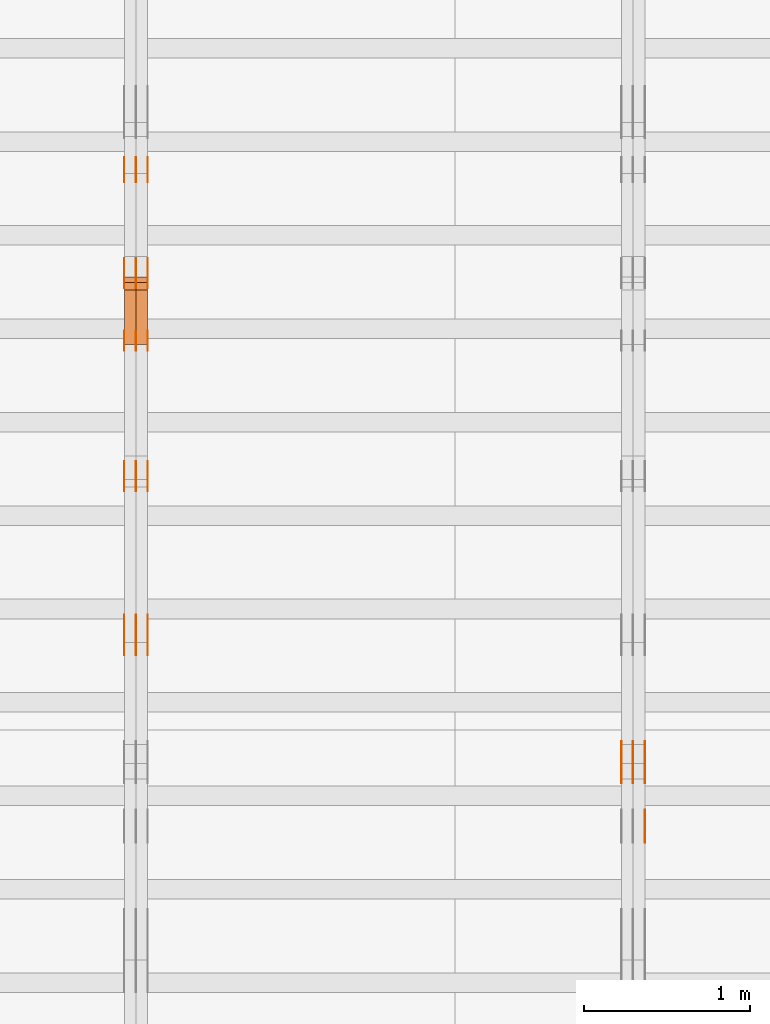
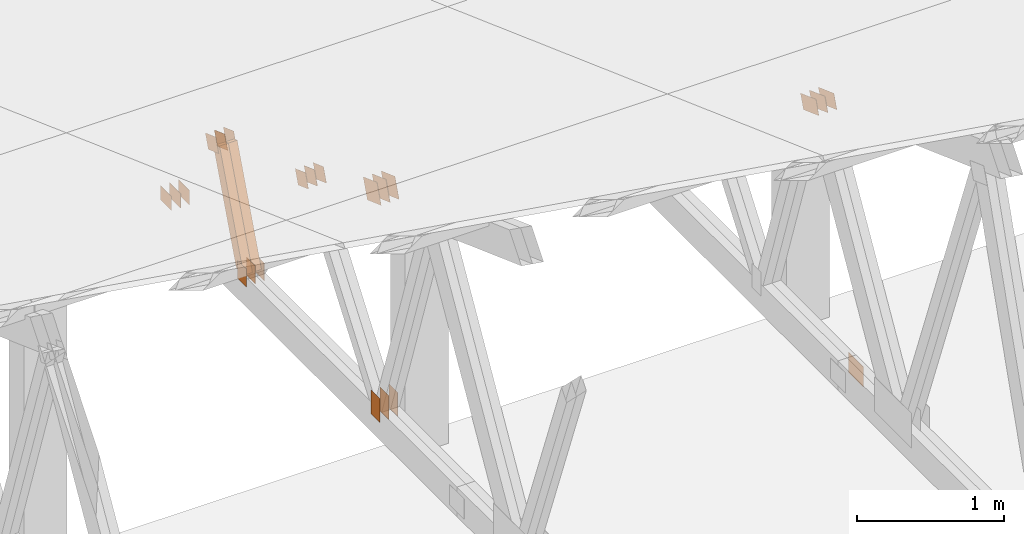
# One storey, part 165 of 189: 31 proxies.
"""IFC2X3 building model written with IfcOpenShell, lengths in millimetres."""

from ifc_helpers import new_model, entity, si_unit, converted_unit, derived_unit, direction, frame, frame_2d, origin, origin_2d_with_axis, place, context, subcontext, project, spatial, polyline, rectangle, outline, extrude, source, transform, mapped, material, type_object, type_shapes, element, save


model = new_model("IFC2X3")

# Units and contexts
model_context = context("Model", 3, precision=0.01, world=origin(), true_north=direction((6.12303176911189e-17, 1.0)))
body_context = subcontext(model_context, "Body", "Model", "MODEL_VIEW")
ifc_project = project(units=[si_unit("LENGTHUNIT", "METRE", prefix="MILLI"), si_unit("AREAUNIT", "SQUARE_METRE"), si_unit("VOLUMEUNIT", "CUBIC_METRE"), converted_unit("PLANEANGLEUNIT", "DEGREE", entity("IfcRatioMeasure", 0.0174532925199433), si_unit("PLANEANGLEUNIT", "RADIAN"), dimensions=[0, 0, 0, 0, 0, 0, 0]), si_unit("MASSUNIT", "GRAM", prefix="KILO"), derived_unit("MASSDENSITYUNIT", [(si_unit("MASSUNIT", "GRAM", prefix="KILO"), 1), (si_unit("LENGTHUNIT", "METRE"), -3)]), si_unit("TIMEUNIT", "SECOND"), si_unit("FREQUENCYUNIT", "HERTZ"), si_unit("THERMODYNAMICTEMPERATUREUNIT", "DEGREE_CELSIUS"), derived_unit("THERMALTRANSMITTANCEUNIT", [(si_unit("MASSUNIT", "GRAM", prefix="KILO"), 1), (si_unit("THERMODYNAMICTEMPERATUREUNIT", "KELVIN"), -1), (si_unit("TIMEUNIT", "SECOND"), -3)]), derived_unit("VOLUMETRICFLOWRATEUNIT", [(si_unit("LENGTHUNIT", "METRE"), 3), (si_unit("TIMEUNIT", "SECOND"), -1)]), si_unit("ELECTRICCURRENTUNIT", "AMPERE"), si_unit("ELECTRICVOLTAGEUNIT", "VOLT"), si_unit("POWERUNIT", "WATT"), si_unit("FORCEUNIT", "NEWTON"), si_unit("ILLUMINANCEUNIT", "LUX"), si_unit("LUMINOUSFLUXUNIT", "LUMEN"), si_unit("LUMINOUSINTENSITYUNIT", "CANDELA"), derived_unit("USERDEFINED", [(si_unit("MASSUNIT", "GRAM", prefix="KILO"), -1), (si_unit("LENGTHUNIT", "METRE"), -2), (si_unit("TIMEUNIT", "SECOND"), 3), (si_unit("LUMINOUSFLUXUNIT", "LUMEN"), 1)]), derived_unit("LINEARVELOCITYUNIT", [(si_unit("LENGTHUNIT", "METRE"), 1), (si_unit("TIMEUNIT", "SECOND"), -1)]), si_unit("PRESSUREUNIT", "PASCAL"), derived_unit("USERDEFINED", [(si_unit("LENGTHUNIT", "METRE"), -2), (si_unit("MASSUNIT", "GRAM", prefix="KILO"), 1), (si_unit("TIMEUNIT", "SECOND"), -2)])], contexts=[model_context])

# Site, building, storey
site_placement = place(None, origin())
site = spatial("IfcSite", under=ifc_project, at=site_placement, CompositionType="ELEMENT")
building_placement = place(site_placement, origin())
building = spatial("IfcBuilding", under=site, at=building_placement, CompositionType="ELEMENT")
storey_placement = place(building_placement, origin())
storey = spatial("IfcBuildingStorey", under=building, at=storey_placement, Name="Default", CompositionType="ELEMENT", Elevation=0.0)

# Proxies
ifc_material_1 = material(Name="IfcSurfaceStyle #201218")
building_element_proxy_type_1 = type_object("IfcBuildingElementProxyType", PredefinedType="NOTDEFINED", material=ifc_material_1)
shared_shape_1 = source(origin(), body_context, "Body", "SweptSolid", [
    extrude(outline(polyline([(-112.499846801582, -59.999986193028), (112.499924372729, -59.999986193028), (112.499888552087, 59.999986193028), (-112.499966123235, 59.999986193028), (-112.499846801582, -59.999986193028)])), frame((112.499989807712, 60.0001003787081, 0.0), z_axis=(0.0, 0.0, 1.0), x_axis=(-1.0, 0.0, 0.0)), (0.0, 0.0, 1.0), 1.3),
])
type_shapes(building_element_proxy_type_1, [shared_shape_1])
proxy_1_placement = place(building_placement, frame((36301.3, 24040.8868138992, 2049.61031693104), z_axis=(-1.0, 0.0, 0.0), x_axis=(0.0, -0.939692620785908, 0.342020143325669)))
element("IfcBuildingElementProxy", 1, at=proxy_1_placement, inside=storey, type_object=building_element_proxy_type_1, material=ifc_material_1, context=body_context, shape_type="MappedRepresentation", body=[
    mapped(shared_shape_1, transform((0.0, 0.0, 0.0), scale=1.0)),
])
ifc_material_2 = material(Name="IfcSurfaceStyle #201161")
building_element_proxy_type_2 = type_object("IfcBuildingElementProxyType", PredefinedType="NOTDEFINED", material=ifc_material_2)
shared_shape_2 = source(origin(), body_context, "Body", "SweptSolid", [
    extrude(outline(polyline([(-112.499846801582, -59.999986193028), (112.499924372729, -59.999986193028), (112.499888552087, 59.999986193028), (-112.499966123235, 59.999986193028), (-112.499846801582, -59.999986193028)])), frame((112.499989807712, 60.0001003787081, 0.0), z_axis=(0.0, 0.0, 1.0), x_axis=(-1.0, 0.0, 0.0)), (0.0, 0.0, 1.0), 1.29999999999998),
])
type_shapes(building_element_proxy_type_2, [shared_shape_2])
proxy_2_placement = place(building_placement, frame((36230.0, 24040.8868138992, 2049.61031693104), z_axis=(-1.0, 0.0, 0.0), x_axis=(0.0, -0.939692620785908, 0.342020143325669)))
element("IfcBuildingElementProxy", 2, at=proxy_2_placement, inside=storey, type_object=building_element_proxy_type_2, material=ifc_material_2, context=body_context, shape_type="MappedRepresentation", body=[
    mapped(shared_shape_2, transform((0.0, 0.0, 0.0), scale=1.0)),
])
ifc_material_3 = material(Name="IfcSurfaceStyle #201104")
building_element_proxy_type_3 = type_object("IfcBuildingElementProxyType", PredefinedType="NOTDEFINED", material=ifc_material_3)
shared_shape_3 = source(origin(), body_context, "Body", "SweptSolid", [
    extrude(outline(polyline([(-112.499846801582, -59.999986193028), (112.499924372729, -59.999986193028), (112.499888552087, 59.999986193028), (-112.499966123235, 59.999986193028), (-112.499846801582, -59.999986193028)])), frame((112.499989807712, 60.0001003787081, 0.0), z_axis=(0.0, 0.0, 1.0), x_axis=(-1.0, 0.0, 0.0)), (0.0, 0.0, 1.0), 1.29999999999998),
])
type_shapes(building_element_proxy_type_3, [shared_shape_3])
proxy_3_placement = place(building_placement, frame((36231.3, 24040.8868138992, 2049.61031693104), z_axis=(-1.0, 0.0, 0.0), x_axis=(0.0, -0.939692620785908, 0.342020143325669)))
element("IfcBuildingElementProxy", 3, at=proxy_3_placement, inside=storey, type_object=building_element_proxy_type_3, material=ifc_material_3, context=body_context, shape_type="MappedRepresentation", body=[
    mapped(shared_shape_3, transform((0.0, 0.0, 0.0), scale=1.0)),
])
ifc_material_4 = material(Name="IfcSurfaceStyle #201047")
building_element_proxy_type_4 = type_object("IfcBuildingElementProxyType", PredefinedType="NOTDEFINED", material=ifc_material_4)
shared_shape_4 = source(origin(), body_context, "Body", "SweptSolid", [
    extrude(outline(polyline([(-112.499846801582, -59.999986193028), (112.499924372729, -59.999986193028), (112.499888552087, 59.999986193028), (-112.499966123235, 59.999986193028), (-112.499846801582, -59.999986193028)])), frame((112.499989807712, 60.0001003787081, 0.0), z_axis=(0.0, 0.0, 1.0), x_axis=(-1.0, 0.0, 0.0)), (0.0, 0.0, 1.0), 1.29999999999999),
])
type_shapes(building_element_proxy_type_4, [shared_shape_4])
proxy_4_placement = place(building_placement, frame((36160.0, 24040.8868138992, 2049.61031693104), z_axis=(-1.0, 0.0, 0.0), x_axis=(0.0, -0.939692620785908, 0.342020143325669)))
element("IfcBuildingElementProxy", 4, at=proxy_4_placement, inside=storey, type_object=building_element_proxy_type_4, material=ifc_material_4, context=body_context, shape_type="MappedRepresentation", body=[
    mapped(shared_shape_4, transform((0.0, 0.0, 0.0), scale=1.0)),
])
ifc_material_5 = material(Name="IfcSurfaceStyle #197342")
building_element_proxy_type_5 = type_object("IfcBuildingElementProxyType", PredefinedType="NOTDEFINED", material=ifc_material_5)
shared_shape_5 = source(origin(), body_context, "Body", "SweptSolid", [
    extrude(rectangle(XDim=200.0, YDim=168.0, at=origin_2d_with_axis()), frame((100.0, 84.0, 0.0), z_axis=(0.0, 0.0, 1.0), x_axis=(-1.0, 0.0, 0.0)), (0.0, 0.0, 1.0), 1.3),
])
type_shapes(building_element_proxy_type_5, [shared_shape_5])
proxy_5_placement = place(building_placement, frame((36301.3, 23470.0, 206.5), z_axis=(-1.0, 0.0, 0.0), x_axis=(0.0, 1.0, 0.0)))
element("IfcBuildingElementProxy", 5, at=proxy_5_placement, inside=storey, type_object=building_element_proxy_type_5, material=ifc_material_5, context=body_context, shape_type="MappedRepresentation", body=[
    mapped(shared_shape_5, transform((0.0, 0.0, 0.0), scale=1.0)),
])
ifc_material_6 = material(Name="IfcSurfaceStyle #185200")
building_element_proxy_type_6 = type_object("IfcBuildingElementProxyType", PredefinedType="NOTDEFINED", material=ifc_material_6)
shared_shape_6 = source(origin(), body_context, "Body", "SweptSolid", [
    extrude(rectangle(XDim=200.0, YDim=120.0, at=origin_2d_with_axis()), frame((100.0, 60.0002296775929, 0.0), z_axis=(0.0, 0.0, 1.0), x_axis=(-1.0, 0.0, 0.0)), (0.0, 0.0, 1.0), 1.3),
])
type_shapes(building_element_proxy_type_6, [shared_shape_6])
proxy_6_placement = place(building_placement, frame((33301.3, 24619.3435203224, 145.0), z_axis=(-1.0, 0.0, 0.0), x_axis=(0.0, 0.0, 1.0)))
element("IfcBuildingElementProxy", 6, at=proxy_6_placement, inside=storey, type_object=building_element_proxy_type_6, material=ifc_material_6, context=body_context, shape_type="MappedRepresentation", body=[
    mapped(shared_shape_6, transform((0.0, 0.0, 0.0), scale=1.0)),
])
ifc_material_7 = material(Name="IfcSurfaceStyle #185143")
building_element_proxy_type_7 = type_object("IfcBuildingElementProxyType", PredefinedType="NOTDEFINED", material=ifc_material_7)
shared_shape_7 = source(origin(), body_context, "Body", "SweptSolid", [
    extrude(rectangle(XDim=200.0, YDim=120.0, at=origin_2d_with_axis()), frame((100.0, 60.0002296775929, 0.0), z_axis=(0.0, 0.0, 1.0), x_axis=(-1.0, 0.0, 0.0)), (0.0, 0.0, 1.0), 1.29999999999998),
])
type_shapes(building_element_proxy_type_7, [shared_shape_7])
proxy_7_placement = place(building_placement, frame((33230.0, 24619.3435203224, 145.0), z_axis=(-1.0, 0.0, 0.0), x_axis=(0.0, 0.0, 1.0)))
element("IfcBuildingElementProxy", 7, at=proxy_7_placement, inside=storey, type_object=building_element_proxy_type_7, material=ifc_material_7, context=body_context, shape_type="MappedRepresentation", body=[
    mapped(shared_shape_7, transform((0.0, 0.0, 0.0), scale=1.0)),
])
ifc_material_8 = material(Name="IfcSurfaceStyle #185086")
building_element_proxy_type_8 = type_object("IfcBuildingElementProxyType", PredefinedType="NOTDEFINED", material=ifc_material_8)
shared_shape_8 = source(origin(), body_context, "Body", "SweptSolid", [
    extrude(rectangle(XDim=200.0, YDim=120.0, at=origin_2d_with_axis()), frame((100.0, 60.0002296775929, 0.0), z_axis=(0.0, 0.0, 1.0), x_axis=(-1.0, 0.0, 0.0)), (0.0, 0.0, 1.0), 1.29999999999998),
])
type_shapes(building_element_proxy_type_8, [shared_shape_8])
proxy_8_placement = place(building_placement, frame((33231.3, 24619.3435203224, 145.0), z_axis=(-1.0, 0.0, 0.0), x_axis=(0.0, 0.0, 1.0)))
element("IfcBuildingElementProxy", 8, at=proxy_8_placement, inside=storey, type_object=building_element_proxy_type_8, material=ifc_material_8, context=body_context, shape_type="MappedRepresentation", body=[
    mapped(shared_shape_8, transform((0.0, 0.0, 0.0), scale=1.0)),
])
ifc_material_9 = material(Name="IfcSurfaceStyle #185029")
building_element_proxy_type_9 = type_object("IfcBuildingElementProxyType", PredefinedType="NOTDEFINED", material=ifc_material_9)
shared_shape_9 = source(origin(), body_context, "Body", "SweptSolid", [
    extrude(rectangle(XDim=200.0, YDim=120.0, at=origin_2d_with_axis()), frame((100.0, 60.0002296775929, 0.0), z_axis=(0.0, 0.0, 1.0), x_axis=(-1.0, 0.0, 0.0)), (0.0, 0.0, 1.0), 1.29999999999999),
])
type_shapes(building_element_proxy_type_9, [shared_shape_9])
proxy_9_placement = place(building_placement, frame((33160.0, 24619.3435203224, 145.0), z_axis=(-1.0, 0.0, 0.0), x_axis=(0.0, 0.0, 1.0)))
element("IfcBuildingElementProxy", 9, at=proxy_9_placement, inside=storey, type_object=building_element_proxy_type_9, material=ifc_material_9, context=body_context, shape_type="MappedRepresentation", body=[
    mapped(shared_shape_9, transform((0.0, 0.0, 0.0), scale=1.0)),
])
ifc_material_10 = material(Name="IfcSurfaceStyle #184516")
building_element_proxy_type_10 = type_object("IfcBuildingElementProxyType", PredefinedType="NOTDEFINED", material=ifc_material_10)
shared_shape_10 = source(origin(), body_context, "Body", "SweptSolid", [
    extrude(outline(polyline([(-74.9999475298494, -60.0), (75.0000042257432, -60.0), (74.9999684051025, 60.0), (-75.0000251009963, 60.0), (-74.9999475298494, -60.0)])), frame((75.0000607644577, 60.0000865490217, 0.0), z_axis=(0.0, 0.0, 1.0), x_axis=(-1.0, 0.0, 0.0)), (0.0, 0.0, 1.0), 1.3),
])
type_shapes(building_element_proxy_type_10, [shared_shape_10])
proxy_10_placement = place(building_placement, frame((33301.3, 25732.0586805394, 1446.84420669249), z_axis=(-1.0, 0.0, 0.0), x_axis=(0.0, -0.939692620785908, 0.342020143325669)))
element("IfcBuildingElementProxy", 10, at=proxy_10_placement, inside=storey, type_object=building_element_proxy_type_10, material=ifc_material_10, context=body_context, shape_type="MappedRepresentation", body=[
    mapped(shared_shape_10, transform((0.0, 0.0, 0.0), scale=1.0)),
])
ifc_material_11 = material(Name="IfcSurfaceStyle #184459")
building_element_proxy_type_11 = type_object("IfcBuildingElementProxyType", PredefinedType="NOTDEFINED", material=ifc_material_11)
shared_shape_11 = source(origin(), body_context, "Body", "SweptSolid", [
    extrude(outline(polyline([(-74.9999475298494, -60.0), (75.0000042257432, -60.0), (74.9999684051025, 60.0), (-75.0000251009963, 60.0), (-74.9999475298494, -60.0)])), frame((75.0000607644577, 60.0000865490217, 0.0), z_axis=(0.0, 0.0, 1.0), x_axis=(-1.0, 0.0, 0.0)), (0.0, 0.0, 1.0), 1.29999999999999),
])
type_shapes(building_element_proxy_type_11, [shared_shape_11])
proxy_11_placement = place(building_placement, frame((33230.0, 25732.0586805394, 1446.84420669249), z_axis=(-1.0, 0.0, 0.0), x_axis=(0.0, -0.939692620785908, 0.342020143325669)))
element("IfcBuildingElementProxy", 11, at=proxy_11_placement, inside=storey, type_object=building_element_proxy_type_11, material=ifc_material_11, context=body_context, shape_type="MappedRepresentation", body=[
    mapped(shared_shape_11, transform((0.0, 0.0, 0.0), scale=1.0)),
])
ifc_material_12 = material(Name="IfcSurfaceStyle #184402")
building_element_proxy_type_12 = type_object("IfcBuildingElementProxyType", PredefinedType="NOTDEFINED", material=ifc_material_12)
shared_shape_12 = source(origin(), body_context, "Body", "SweptSolid", [
    extrude(outline(polyline([(-74.9999475298494, -60.0), (75.0000042257432, -60.0), (74.9999684051025, 60.0), (-75.0000251009963, 60.0), (-74.9999475298494, -60.0)])), frame((75.0000607644577, 60.0000865490217, 0.0), z_axis=(0.0, 0.0, 1.0), x_axis=(-1.0, 0.0, 0.0)), (0.0, 0.0, 1.0), 1.29999999999999),
])
type_shapes(building_element_proxy_type_12, [shared_shape_12])
proxy_12_placement = place(building_placement, frame((33231.3, 25732.0586805394, 1446.84420669249), z_axis=(-1.0, 0.0, 0.0), x_axis=(0.0, -0.939692620785908, 0.342020143325669)))
element("IfcBuildingElementProxy", 12, at=proxy_12_placement, inside=storey, type_object=building_element_proxy_type_12, material=ifc_material_12, context=body_context, shape_type="MappedRepresentation", body=[
    mapped(shared_shape_12, transform((0.0, 0.0, 0.0), scale=1.0)),
])
ifc_material_13 = material(Name="IfcSurfaceStyle #184345")
building_element_proxy_type_13 = type_object("IfcBuildingElementProxyType", PredefinedType="NOTDEFINED", material=ifc_material_13)
shared_shape_13 = source(origin(), body_context, "Body", "SweptSolid", [
    extrude(outline(polyline([(-74.9999475298494, -60.0), (75.0000042257432, -60.0), (74.9999684051025, 60.0), (-75.0000251009963, 60.0), (-74.9999475298494, -60.0)])), frame((75.0000607644577, 60.0000865490217, 0.0), z_axis=(0.0, 0.0, 1.0), x_axis=(-1.0, 0.0, 0.0)), (0.0, 0.0, 1.0), 1.29999999999999),
])
type_shapes(building_element_proxy_type_13, [shared_shape_13])
proxy_13_placement = place(building_placement, frame((33160.0, 25732.0586805394, 1446.84420669249), z_axis=(-1.0, 0.0, 0.0), x_axis=(0.0, -0.939692620785908, 0.342020143325669)))
element("IfcBuildingElementProxy", 13, at=proxy_13_placement, inside=storey, type_object=building_element_proxy_type_13, material=ifc_material_13, context=body_context, shape_type="MappedRepresentation", body=[
    mapped(shared_shape_13, transform((0.0, 0.0, 0.0), scale=1.0)),
])
ifc_material_14 = material(Name="IfcSurfaceStyle #184288")
building_element_proxy_type_14 = type_object("IfcBuildingElementProxyType", PredefinedType="NOTDEFINED", material=ifc_material_14)
shared_shape_14 = source(origin(), body_context, "Body", "SweptSolid", [
    extrude(rectangle(XDim=150.0, YDim=120.0, at=frame_2d((-7.105427357601e-15, 0.0), x_axis=(1.0, 0.0))), frame((75.0, 60.0, 0.0), z_axis=(0.0, 0.0, 1.0), x_axis=(-1.0, 0.0, 0.0)), (0.0, 0.0, 1.0), 1.3),
])
type_shapes(building_element_proxy_type_14, [shared_shape_14])
proxy_14_placement = place(building_placement, frame((33301.3, 26439.0083007813, 170.0), z_axis=(-1.0, 0.0, 0.0), x_axis=(0.0, 0.0, 1.0)))
element("IfcBuildingElementProxy", 14, at=proxy_14_placement, inside=storey, type_object=building_element_proxy_type_14, material=ifc_material_14, context=body_context, shape_type="MappedRepresentation", body=[
    mapped(shared_shape_14, transform((0.0, 0.0, 0.0), scale=1.0)),
])
ifc_material_15 = material(Name="IfcSurfaceStyle #184231")
building_element_proxy_type_15 = type_object("IfcBuildingElementProxyType", PredefinedType="NOTDEFINED", material=ifc_material_15)
shared_shape_15 = source(origin(), body_context, "Body", "SweptSolid", [
    extrude(rectangle(XDim=150.0, YDim=120.0, at=frame_2d((-7.105427357601e-15, 0.0), x_axis=(1.0, 0.0))), frame((75.0, 60.0, 0.0), z_axis=(0.0, 0.0, 1.0), x_axis=(-1.0, 0.0, 0.0)), (0.0, 0.0, 1.0), 1.29999999999999),
])
type_shapes(building_element_proxy_type_15, [shared_shape_15])
proxy_15_placement = place(building_placement, frame((33230.0, 26439.0083007813, 170.0), z_axis=(-1.0, 0.0, 0.0), x_axis=(0.0, 0.0, 1.0)))
element("IfcBuildingElementProxy", 15, at=proxy_15_placement, inside=storey, type_object=building_element_proxy_type_15, material=ifc_material_15, context=body_context, shape_type="MappedRepresentation", body=[
    mapped(shared_shape_15, transform((0.0, 0.0, 0.0), scale=1.0)),
])
ifc_material_16 = material(Name="IfcSurfaceStyle #184174")
building_element_proxy_type_16 = type_object("IfcBuildingElementProxyType", PredefinedType="NOTDEFINED", material=ifc_material_16)
shared_shape_16 = source(origin(), body_context, "Body", "SweptSolid", [
    extrude(rectangle(XDim=150.0, YDim=120.0, at=frame_2d((-7.105427357601e-15, 0.0), x_axis=(1.0, 0.0))), frame((75.0, 60.0, 0.0), z_axis=(0.0, 0.0, 1.0), x_axis=(-1.0, 0.0, 0.0)), (0.0, 0.0, 1.0), 1.29999999999999),
])
type_shapes(building_element_proxy_type_16, [shared_shape_16])
proxy_16_placement = place(building_placement, frame((33231.3, 26439.0083007813, 170.0), z_axis=(-1.0, 0.0, 0.0), x_axis=(0.0, 0.0, 1.0)))
element("IfcBuildingElementProxy", 16, at=proxy_16_placement, inside=storey, type_object=building_element_proxy_type_16, material=ifc_material_16, context=body_context, shape_type="MappedRepresentation", body=[
    mapped(shared_shape_16, transform((0.0, 0.0, 0.0), scale=1.0)),
])
ifc_material_17 = material(Name="IfcSurfaceStyle #184117")
building_element_proxy_type_17 = type_object("IfcBuildingElementProxyType", PredefinedType="NOTDEFINED", material=ifc_material_17)
shared_shape_17 = source(origin(), body_context, "Body", "SweptSolid", [
    extrude(rectangle(XDim=150.0, YDim=120.0, at=frame_2d((-7.105427357601e-15, 0.0), x_axis=(1.0, 0.0))), frame((75.0, 60.0, 0.0), z_axis=(0.0, 0.0, 1.0), x_axis=(-1.0, 0.0, 0.0)), (0.0, 0.0, 1.0), 1.29999999999999),
])
type_shapes(building_element_proxy_type_17, [shared_shape_17])
proxy_17_placement = place(building_placement, frame((33160.0, 26439.0083007813, 170.0), z_axis=(-1.0, 0.0, 0.0), x_axis=(0.0, 0.0, 1.0)))
element("IfcBuildingElementProxy", 17, at=proxy_17_placement, inside=storey, type_object=building_element_proxy_type_17, material=ifc_material_17, context=body_context, shape_type="MappedRepresentation", body=[
    mapped(shared_shape_17, transform((0.0, 0.0, 0.0), scale=1.0)),
])
ifc_material_18 = material(Name="IfcSurfaceStyle #183604")
building_element_proxy_type_18 = type_object("IfcBuildingElementProxyType", PredefinedType="NOTDEFINED", material=ifc_material_18)
shared_shape_18 = source(origin(), body_context, "Body", "SweptSolid", [
    extrude(outline(polyline([(-74.9999684051023, -60.0), (75.0000251009964, -60.0), (74.9999475298495, 60.0), (-75.0000042257435, 60.0), (-74.9999684051023, -60.0)])), frame((75.0000251009964, 60.0000006265238, 0.0), z_axis=(0.0, 0.0, 1.0), x_axis=(-1.0, 0.0, 0.0)), (0.0, 0.0, 1.0), 1.3),
])
type_shapes(building_element_proxy_type_18, [shared_shape_18])
proxy_18_placement = place(building_placement, frame((33301.3, 26956.490053282, 1001.18769055967), z_axis=(-1.0, 0.0, 0.0), x_axis=(0.0, -0.939692620785908, 0.342020143325669)))
element("IfcBuildingElementProxy", 18, at=proxy_18_placement, inside=storey, type_object=building_element_proxy_type_18, material=ifc_material_18, context=body_context, shape_type="MappedRepresentation", body=[
    mapped(shared_shape_18, transform((0.0, 0.0, 0.0), scale=1.0)),
])
ifc_material_19 = material(Name="IfcSurfaceStyle #183547")
building_element_proxy_type_19 = type_object("IfcBuildingElementProxyType", PredefinedType="NOTDEFINED", material=ifc_material_19)
shared_shape_19 = source(origin(), body_context, "Body", "SweptSolid", [
    extrude(outline(polyline([(-74.9999684051023, -60.0), (75.0000251009964, -60.0), (74.9999475298495, 60.0), (-75.0000042257435, 60.0), (-74.9999684051023, -60.0)])), frame((75.0000251009964, 60.0000006265238, 0.0), z_axis=(0.0, 0.0, 1.0), x_axis=(-1.0, 0.0, 0.0)), (0.0, 0.0, 1.0), 1.29999999999999),
])
type_shapes(building_element_proxy_type_19, [shared_shape_19])
proxy_19_placement = place(building_placement, frame((33230.0, 26956.490053282, 1001.18769055967), z_axis=(-1.0, 0.0, 0.0), x_axis=(0.0, -0.939692620785908, 0.342020143325669)))
element("IfcBuildingElementProxy", 19, at=proxy_19_placement, inside=storey, type_object=building_element_proxy_type_19, material=ifc_material_19, context=body_context, shape_type="MappedRepresentation", body=[
    mapped(shared_shape_19, transform((0.0, 0.0, 0.0), scale=1.0)),
])
ifc_material_20 = material(Name="IfcSurfaceStyle #183490")
building_element_proxy_type_20 = type_object("IfcBuildingElementProxyType", PredefinedType="NOTDEFINED", material=ifc_material_20)
shared_shape_20 = source(origin(), body_context, "Body", "SweptSolid", [
    extrude(outline(polyline([(-74.9999684051023, -60.0), (75.0000251009964, -60.0), (74.9999475298495, 60.0), (-75.0000042257435, 60.0), (-74.9999684051023, -60.0)])), frame((75.0000251009964, 60.0000006265238, 0.0), z_axis=(0.0, 0.0, 1.0), x_axis=(-1.0, 0.0, 0.0)), (0.0, 0.0, 1.0), 1.29999999999999),
])
type_shapes(building_element_proxy_type_20, [shared_shape_20])
proxy_20_placement = place(building_placement, frame((33231.3, 26956.490053282, 1001.18769055967), z_axis=(-1.0, 0.0, 0.0), x_axis=(0.0, -0.939692620785908, 0.342020143325669)))
element("IfcBuildingElementProxy", 20, at=proxy_20_placement, inside=storey, type_object=building_element_proxy_type_20, material=ifc_material_20, context=body_context, shape_type="MappedRepresentation", body=[
    mapped(shared_shape_20, transform((0.0, 0.0, 0.0), scale=1.0)),
])
ifc_material_21 = material(Name="IfcSurfaceStyle #183433")
building_element_proxy_type_21 = type_object("IfcBuildingElementProxyType", PredefinedType="NOTDEFINED", material=ifc_material_21)
shared_shape_21 = source(origin(), body_context, "Body", "SweptSolid", [
    extrude(outline(polyline([(-74.9999684051023, -60.0), (75.0000251009964, -60.0), (74.9999475298495, 60.0), (-75.0000042257435, 60.0), (-74.9999684051023, -60.0)])), frame((75.0000251009964, 60.0000006265238, 0.0), z_axis=(0.0, 0.0, 1.0), x_axis=(-1.0, 0.0, 0.0)), (0.0, 0.0, 1.0), 1.29999999999999),
])
type_shapes(building_element_proxy_type_21, [shared_shape_21])
proxy_21_placement = place(building_placement, frame((33160.0, 26956.490053282, 1001.18769055967), z_axis=(-1.0, 0.0, 0.0), x_axis=(0.0, -0.939692620785908, 0.342020143325669)))
element("IfcBuildingElementProxy", 21, at=proxy_21_placement, inside=storey, type_object=building_element_proxy_type_21, material=ifc_material_21, context=body_context, shape_type="MappedRepresentation", body=[
    mapped(shared_shape_21, transform((0.0, 0.0, 0.0), scale=1.0)),
])
ifc_material_22 = material(Name="IfcSurfaceStyle #183376")
building_element_proxy_type_22 = type_object("IfcBuildingElementProxyType", PredefinedType="NOTDEFINED", material=ifc_material_22)
shared_shape_22 = source(origin(), body_context, "Body", "SweptSolid", [
    extrude(rectangle(XDim=150.0, YDim=120.0, at=origin_2d_with_axis()), frame((75.0, 60.0, 0.0), z_axis=(0.0, 0.0, 1.0), x_axis=(-1.0, 0.0, 0.0)), (0.0, 0.0, 1.0), 1.3),
])
type_shapes(building_element_proxy_type_22, [shared_shape_22])
proxy_22_placement = place(building_placement, frame((33301.3, 27607.3129882813, 185.0), z_axis=(-1.0, 0.0, 0.0), x_axis=(0.0, -1.0, 0.0)))
element("IfcBuildingElementProxy", 22, at=proxy_22_placement, inside=storey, type_object=building_element_proxy_type_22, material=ifc_material_22, context=body_context, shape_type="MappedRepresentation", body=[
    mapped(shared_shape_22, transform((0.0, 0.0, 0.0), scale=1.0)),
])
ifc_material_23 = material(Name="IfcSurfaceStyle #183319")
building_element_proxy_type_23 = type_object("IfcBuildingElementProxyType", PredefinedType="NOTDEFINED", material=ifc_material_23)
shared_shape_23 = source(origin(), body_context, "Body", "SweptSolid", [
    extrude(rectangle(XDim=150.0, YDim=120.0, at=origin_2d_with_axis()), frame((75.0, 60.0, 0.0), z_axis=(0.0, 0.0, 1.0), x_axis=(-1.0, 0.0, 0.0)), (0.0, 0.0, 1.0), 1.29999999999999),
])
type_shapes(building_element_proxy_type_23, [shared_shape_23])
proxy_23_placement = place(building_placement, frame((33230.0, 27607.3129882813, 185.0), z_axis=(-1.0, 0.0, 0.0), x_axis=(0.0, -1.0, 0.0)))
element("IfcBuildingElementProxy", 23, at=proxy_23_placement, inside=storey, type_object=building_element_proxy_type_23, material=ifc_material_23, context=body_context, shape_type="MappedRepresentation", body=[
    mapped(shared_shape_23, transform((0.0, 0.0, 0.0), scale=1.0)),
])
ifc_material_24 = material(Name="IfcSurfaceStyle #183262")
building_element_proxy_type_24 = type_object("IfcBuildingElementProxyType", PredefinedType="NOTDEFINED", material=ifc_material_24)
shared_shape_24 = source(origin(), body_context, "Body", "SweptSolid", [
    extrude(rectangle(XDim=150.0, YDim=120.0, at=origin_2d_with_axis()), frame((75.0, 60.0, 0.0), z_axis=(0.0, 0.0, 1.0), x_axis=(-1.0, 0.0, 0.0)), (0.0, 0.0, 1.0), 1.29999999999999),
])
type_shapes(building_element_proxy_type_24, [shared_shape_24])
proxy_24_placement = place(building_placement, frame((33231.3, 27607.3129882813, 185.0), z_axis=(-1.0, 0.0, 0.0), x_axis=(0.0, -1.0, 0.0)))
element("IfcBuildingElementProxy", 24, at=proxy_24_placement, inside=storey, type_object=building_element_proxy_type_24, material=ifc_material_24, context=body_context, shape_type="MappedRepresentation", body=[
    mapped(shared_shape_24, transform((0.0, 0.0, 0.0), scale=1.0)),
])
ifc_material_25 = material(Name="IfcSurfaceStyle #183205")
building_element_proxy_type_25 = type_object("IfcBuildingElementProxyType", PredefinedType="NOTDEFINED", material=ifc_material_25)
shared_shape_25 = source(origin(), body_context, "Body", "SweptSolid", [
    extrude(rectangle(XDim=150.0, YDim=120.0, at=origin_2d_with_axis()), frame((75.0, 60.0, 0.0), z_axis=(0.0, 0.0, 1.0), x_axis=(-1.0, 0.0, 0.0)), (0.0, 0.0, 1.0), 1.29999999999999),
])
type_shapes(building_element_proxy_type_25, [shared_shape_25])
proxy_25_placement = place(building_placement, frame((33160.0, 27607.3129882813, 185.0), z_axis=(-1.0, 0.0, 0.0), x_axis=(0.0, -1.0, 0.0)))
element("IfcBuildingElementProxy", 25, at=proxy_25_placement, inside=storey, type_object=building_element_proxy_type_25, material=ifc_material_25, context=body_context, shape_type="MappedRepresentation", body=[
    mapped(shared_shape_25, transform((0.0, 0.0, 0.0), scale=1.0)),
])
ifc_material_26 = material(Name="IfcSurfaceStyle #179392")
building_element_proxy_type_26 = type_object("IfcBuildingElementProxyType", PredefinedType="NOTDEFINED", material=ifc_material_26)
shared_shape_26 = source(origin(), body_context, "Body", "SweptSolid", [
    extrude(outline(polyline([(-99.9999065788418, -84.0000755647729), (99.9999734279406, -84.0000755647729), (99.9999483293475, 84.000075564773), (-100.000015178446, 84.000075564773), (-99.9999065788418, -84.0000755647729)])), frame((100.000157783747, 84.0001144608011, 0.0), z_axis=(0.0, 0.0, 1.0), x_axis=(-1.0, 0.0, 0.0)), (0.0, 0.0, 1.0), 1.3),
])
type_shapes(building_element_proxy_type_26, [shared_shape_26])
proxy_26_placement = place(building_placement, frame((33301.3, 24788.4767593228, 1895.10136879206), z_axis=(-1.0, 0.0, 0.0), x_axis=(0.0, -0.939692620785908, 0.342020143325669)))
element("IfcBuildingElementProxy", 26, at=proxy_26_placement, inside=storey, type_object=building_element_proxy_type_26, material=ifc_material_26, context=body_context, shape_type="MappedRepresentation", body=[
    mapped(shared_shape_26, transform((0.0, 0.0, 0.0), scale=1.0)),
])
ifc_material_27 = material(Name="IfcSurfaceStyle #179335")
building_element_proxy_type_27 = type_object("IfcBuildingElementProxyType", PredefinedType="NOTDEFINED", material=ifc_material_27)
shared_shape_27 = source(origin(), body_context, "Body", "SweptSolid", [
    extrude(outline(polyline([(-99.9999065788418, -84.0000755647729), (99.9999734279406, -84.0000755647729), (99.9999483293475, 84.000075564773), (-100.000015178446, 84.000075564773), (-99.9999065788418, -84.0000755647729)])), frame((100.000157783747, 84.0001144608011, 0.0), z_axis=(0.0, 0.0, 1.0), x_axis=(-1.0, 0.0, 0.0)), (0.0, 0.0, 1.0), 1.29999999999998),
])
type_shapes(building_element_proxy_type_27, [shared_shape_27])
proxy_27_placement = place(building_placement, frame((33230.0, 24788.4767593228, 1895.10136879206), z_axis=(-1.0, 0.0, 0.0), x_axis=(0.0, -0.939692620785908, 0.342020143325669)))
element("IfcBuildingElementProxy", 27, at=proxy_27_placement, inside=storey, type_object=building_element_proxy_type_27, material=ifc_material_27, context=body_context, shape_type="MappedRepresentation", body=[
    mapped(shared_shape_27, transform((0.0, 0.0, 0.0), scale=1.0)),
])
ifc_material_28 = material(Name="IfcSurfaceStyle #179278")
building_element_proxy_type_28 = type_object("IfcBuildingElementProxyType", PredefinedType="NOTDEFINED", material=ifc_material_28)
shared_shape_28 = source(origin(), body_context, "Body", "SweptSolid", [
    extrude(outline(polyline([(-99.9999065788418, -84.0000755647729), (99.9999734279406, -84.0000755647729), (99.9999483293475, 84.000075564773), (-100.000015178446, 84.000075564773), (-99.9999065788418, -84.0000755647729)])), frame((100.000157783747, 84.0001144608011, 0.0), z_axis=(0.0, 0.0, 1.0), x_axis=(-1.0, 0.0, 0.0)), (0.0, 0.0, 1.0), 1.29999999999998),
])
type_shapes(building_element_proxy_type_28, [shared_shape_28])
proxy_28_placement = place(building_placement, frame((33231.3, 24788.4767593228, 1895.10136879206), z_axis=(-1.0, 0.0, 0.0), x_axis=(0.0, -0.939692620785908, 0.342020143325669)))
element("IfcBuildingElementProxy", 28, at=proxy_28_placement, inside=storey, type_object=building_element_proxy_type_28, material=ifc_material_28, context=body_context, shape_type="MappedRepresentation", body=[
    mapped(shared_shape_28, transform((0.0, 0.0, 0.0), scale=1.0)),
])
ifc_material_29 = material(Name="IfcSurfaceStyle #179221")
building_element_proxy_type_29 = type_object("IfcBuildingElementProxyType", PredefinedType="NOTDEFINED", material=ifc_material_29)
shared_shape_29 = source(origin(), body_context, "Body", "SweptSolid", [
    extrude(outline(polyline([(-99.9999065788418, -84.0000755647729), (99.9999734279406, -84.0000755647729), (99.9999483293475, 84.000075564773), (-100.000015178446, 84.000075564773), (-99.9999065788418, -84.0000755647729)])), frame((100.000157783747, 84.0001144608011, 0.0), z_axis=(0.0, 0.0, 1.0), x_axis=(-1.0, 0.0, 0.0)), (0.0, 0.0, 1.0), 1.29999999999999),
])
type_shapes(building_element_proxy_type_29, [shared_shape_29])
proxy_29_placement = place(building_placement, frame((33160.0, 24788.4767593228, 1895.10136879206), z_axis=(-1.0, 0.0, 0.0), x_axis=(0.0, -0.939692620785908, 0.342020143325669)))
element("IfcBuildingElementProxy", 29, at=proxy_29_placement, inside=storey, type_object=building_element_proxy_type_29, material=ifc_material_29, context=body_context, shape_type="MappedRepresentation", body=[
    mapped(shared_shape_29, transform((0.0, 0.0, 0.0), scale=1.0)),
])
ifc_material_30 = material(Name="IfcSurfaceStyle #176128")
building_element_proxy_type_30 = type_object("IfcBuildingElementProxyType", Name="T1-W14 176126", PredefinedType="NOTDEFINED", material=ifc_material_30)
shared_shape_30 = source(origin(), body_context, "Body", "SweptSolid", [
    extrude(outline(polyline([(-561.981237417233, -47.499947472121), (373.092610496013, -47.499947472121), (373.679602940405, -4.61719047935016e-05), (341.277449358876, 47.4999705580734), (-526.068425378061, 47.4999705580734), (-561.981237417233, -47.499947472121)])), frame((373.679632439416, 47.500120814091, 0.0), z_axis=(0.0, 0.0, 1.0), x_axis=(-1.0, 0.0, 0.0)), (0.0, 0.0, 1.0), 69.9999999999999),
])
type_shapes(building_element_proxy_type_30, [shared_shape_30])
proxy_30_placement = place(building_placement, frame((33300.0, 26895.4809555667, 1086.61918844835), z_axis=(-1.0, 0.0, 0.0), x_axis=(0.0, -0.353606472447933, -0.935394281916951)))
element("IfcBuildingElementProxy", 30, at=proxy_30_placement, inside=storey, type_object=building_element_proxy_type_30, material=ifc_material_30, Name="T1-W14", context=body_context, shape_type="MappedRepresentation", body=[
    mapped(shared_shape_30, transform((0.0, 0.0, 0.0), scale=1.0)),
])
ifc_material_31 = material(Name="IfcSurfaceStyle #176062")
building_element_proxy_type_31 = type_object("IfcBuildingElementProxyType", Name="T1-W14 176060", PredefinedType="NOTDEFINED", material=ifc_material_31)
shared_shape_31 = source(origin(), body_context, "Body", "SweptSolid", [
    extrude(outline(polyline([(-561.981237417233, -47.499947472121), (373.092610496013, -47.499947472121), (373.679602940405, -4.61719047935016e-05), (341.277449358876, 47.4999705580734), (-526.068425378061, 47.4999705580734), (-561.981237417233, -47.499947472121)])), frame((373.679632439416, 47.500120814091, 0.0), z_axis=(0.0, 0.0, 1.0), x_axis=(-1.0, 0.0, 0.0)), (0.0, 0.0, 1.0), 69.9999999999999),
])
type_shapes(building_element_proxy_type_31, [shared_shape_31])
proxy_31_placement = place(building_placement, frame((33230.0, 26895.4809555667, 1086.61918844835), z_axis=(-1.0, 0.0, 0.0), x_axis=(0.0, -0.353606472447933, -0.935394281916951)))
element("IfcBuildingElementProxy", 31, at=proxy_31_placement, inside=storey, type_object=building_element_proxy_type_31, material=ifc_material_31, Name="T1-W14", context=body_context, shape_type="MappedRepresentation", body=[
    mapped(shared_shape_31, transform((0.0, 0.0, 0.0), scale=1.0)),
])

save(model, "model.ifc")
